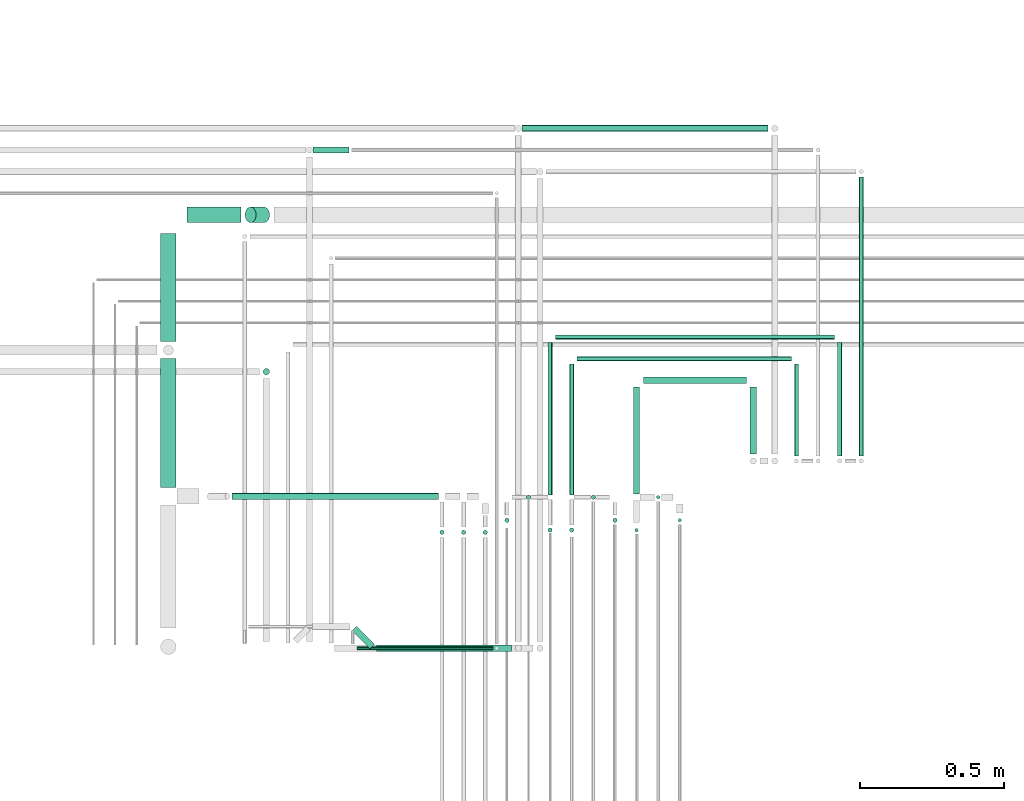
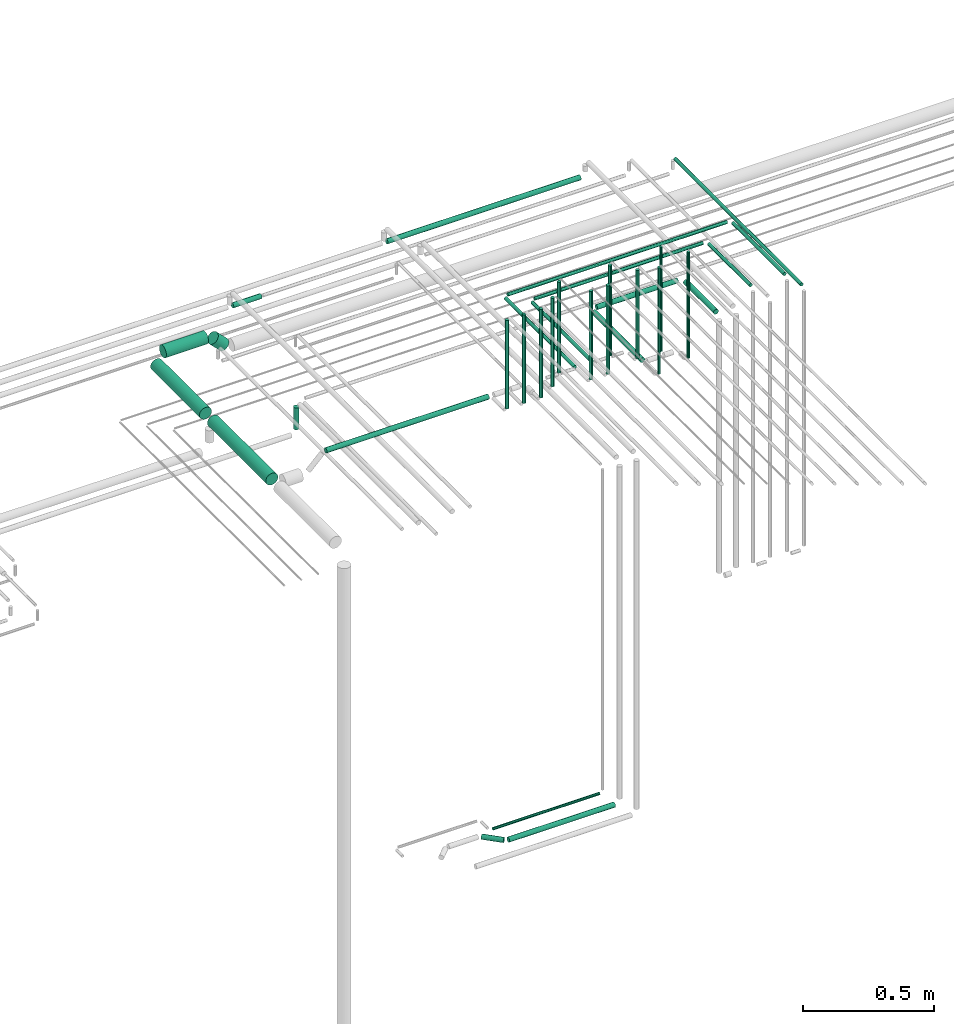
# One storey, part 45 of 65: 33 flow segments.
"""IFC2X3 building model written with IfcOpenShell, lengths in millimetres."""

from ifc_helpers import new_model, entity, si_unit, converted_unit, derived_unit, direction, frame, frame_2d, origin, origin_2d_with_axis, place, context, subcontext, project, spatial, circle, extrude, type_object, element, save


model = new_model("IFC2X3")

# Units and contexts
model_context = context("Model", 3, precision=0.01, world=origin(), true_north=direction((6.12303176911189e-17, 1.0)))
body_context = subcontext(model_context, "Body", "Model", "MODEL_VIEW")
ifc_project = project(units=[si_unit("LENGTHUNIT", "METRE", prefix="MILLI"), si_unit("AREAUNIT", "SQUARE_METRE"), si_unit("VOLUMEUNIT", "CUBIC_METRE"), converted_unit("PLANEANGLEUNIT", "DEGREE", entity("IfcRatioMeasure", 0.0174532925199433), si_unit("PLANEANGLEUNIT", "RADIAN"), dimensions=[0, 0, 0, 0, 0, 0, 0]), si_unit("MASSUNIT", "GRAM", prefix="KILO"), derived_unit("MASSDENSITYUNIT", [(si_unit("MASSUNIT", "GRAM", prefix="KILO"), 1), (si_unit("LENGTHUNIT", "METRE"), -3)]), derived_unit("MOMENTOFINERTIAUNIT", [(si_unit("LENGTHUNIT", "METRE"), 4)]), si_unit("TIMEUNIT", "SECOND"), si_unit("FREQUENCYUNIT", "HERTZ"), si_unit("THERMODYNAMICTEMPERATUREUNIT", "DEGREE_CELSIUS"), derived_unit("THERMALTRANSMITTANCEUNIT", [(si_unit("MASSUNIT", "GRAM", prefix="KILO"), 1), (si_unit("THERMODYNAMICTEMPERATUREUNIT", "KELVIN"), -1), (si_unit("TIMEUNIT", "SECOND"), -3)]), derived_unit("VOLUMETRICFLOWRATEUNIT", [(si_unit("LENGTHUNIT", "METRE"), 3), (si_unit("TIMEUNIT", "SECOND"), -1)]), derived_unit("MASSFLOWRATEUNIT", [(si_unit("MASSUNIT", "GRAM", prefix="KILO"), 1), (si_unit("TIMEUNIT", "SECOND"), -1)]), derived_unit("ROTATIONALFREQUENCYUNIT", [(si_unit("TIMEUNIT", "SECOND"), -1)]), si_unit("ELECTRICCURRENTUNIT", "AMPERE"), si_unit("ELECTRICVOLTAGEUNIT", "VOLT"), si_unit("POWERUNIT", "WATT"), si_unit("FORCEUNIT", "NEWTON", prefix="KILO"), si_unit("ILLUMINANCEUNIT", "LUX"), si_unit("LUMINOUSFLUXUNIT", "LUMEN"), si_unit("LUMINOUSINTENSITYUNIT", "CANDELA"), derived_unit("USERDEFINED", [(si_unit("MASSUNIT", "GRAM", prefix="KILO"), -1), (si_unit("LENGTHUNIT", "METRE"), -2), (si_unit("TIMEUNIT", "SECOND"), 3), (si_unit("LUMINOUSFLUXUNIT", "LUMEN"), 1)]), derived_unit("LINEARVELOCITYUNIT", [(si_unit("LENGTHUNIT", "METRE"), 1), (si_unit("TIMEUNIT", "SECOND"), -1)]), si_unit("PRESSUREUNIT", "PASCAL"), derived_unit("USERDEFINED", [(si_unit("LENGTHUNIT", "METRE"), -2), (si_unit("MASSUNIT", "GRAM", prefix="KILO"), 1), (si_unit("TIMEUNIT", "SECOND"), -2)]), derived_unit("LINEARFORCEUNIT", [(si_unit("MASSUNIT", "GRAM", prefix="KILO"), 1), (si_unit("LENGTHUNIT", "METRE"), 1), (si_unit("TIMEUNIT", "SECOND"), -2), (si_unit("LENGTHUNIT", "METRE"), -1)]), derived_unit("PLANARFORCEUNIT", [(si_unit("MASSUNIT", "GRAM", prefix="KILO"), 1), (si_unit("LENGTHUNIT", "METRE"), 1), (si_unit("TIMEUNIT", "SECOND"), -2), (si_unit("LENGTHUNIT", "METRE"), -2)])], contexts=[model_context])

# Site, building, storey
site_placement = place(None, frame((0.0, -0.00077364408347762, 0.0)))
site = spatial("IfcSite", under=ifc_project, at=site_placement, CompositionType="ELEMENT")
building_placement = place(site_placement, origin())
building = spatial("IfcBuilding", under=site, at=building_placement, CompositionType="ELEMENT")
storey_placement = place(building_placement, frame((0.0, 0.0, 19800.0)))
storey = spatial("IfcBuildingStorey", under=building, at=storey_placement, CompositionType="ELEMENT", Elevation=19800.0)

# Flow segments
pipe_segment_type = type_object("IfcPipeSegmentType", PredefinedType="NOTDEFINED")
flow_segment_1_placement = place(storey_placement, frame((67102.5166110417, 8339.14924977607, 2612.40472776409)))
element("IfcFlowSegment", 1, at=flow_segment_1_placement, inside=storey, type_object=pipe_segment_type, context=body_context, shape_type="SweptSolid", body=[
    extrude(circle(Radius=11.0, at=origin_2d_with_axis()), frame((12.5952722359134, 0.0, 12.5952722359177), z_axis=(0.0, 1.0, 0.0), x_axis=(1.0, 0.0, 0.0)), (0.0, 0.0, 1.0), 232.000000000011),
])
flow_segment_2_placement = place(storey_placement, frame((66734.1118832777, 8582.55397754016, 2612.40472776409)))
element("IfcFlowSegment", 2, at=flow_segment_2_placement, inside=storey, type_object=pipe_segment_type, context=body_context, shape_type="SweptSolid", body=[
    extrude(circle(Radius=11.0, at=frame_2d((1.08286712929839e-12, 0.0), x_axis=(1.0, 0.0))), frame((0.0, 12.5952722359188, 12.5952722359177), z_axis=(1.0, 0.0, 0.0), x_axis=(0.0, 1.0, 0.0)), (0.0, 0.0, 1.0), 356.999999999997),
])
flow_segment_3_placement = place(storey_placement, frame((66312.1118832777, 9456.85739924043, 2537.40472776408)))
element("IfcFlowSegment", 3, at=flow_segment_3_placement, inside=storey, type_object=pipe_segment_type, context=body_context, shape_type="SweptSolid", body=[
    extrude(circle(Radius=11.0, at=origin_2d_with_axis()), frame((0.0, 12.5952722359156, 12.5952722359177), z_axis=(1.0, 0.0, 0.0), x_axis=(0.0, 1.0, 0.0)), (0.0, 0.0, 1.0), 853.999999999996),
])
flow_segment_4_placement = place(storey_placement, frame((65150.1118832777, 9140.85739924042, 2596.4047277641)))
element("IfcFlowSegment", 4, at=flow_segment_4_placement, inside=storey, type_object=pipe_segment_type, context=body_context, shape_type="SweptSolid", body=[
    extrude(circle(Radius=27.0, at=origin_2d_with_axis()), frame((0.0, 28.5952722359206, 28.5952722359141), z_axis=(1.0, 0.0, 0.0), x_axis=(0.0, -1.0, 0.0)), (0.0, 0.0, 1.0), 186.309938476019),
])
flow_segment_5_placement = place(storey_placement, frame((65349.8768020495, 9140.85739924042, 2543.45498029576)))
element("IfcFlowSegment", 5, at=flow_segment_5_placement, inside=storey, type_object=pipe_segment_type, context=body_context, shape_type="SweptSolid", body=[
    extrude(circle(Radius=27.0, at=frame_2d((0.0, -3.06281076100376e-12), x_axis=(1.0, 0.0))), frame((20.687155327948, 28.5952722359163, 67.4028840805148), z_axis=(0.70710678118658, 0.0, -0.707106781186515), x_axis=(0.0, -1.0, 0.0)), (0.0, 0.0, 1.0), 66.0660171780201),
])
flow_segment_6_placement = place(storey_placement, frame((66702.5166110418, 8067.55397754015, 2639.0)))
element("IfcFlowSegment", 6, at=flow_segment_6_placement, inside=storey, type_object=pipe_segment_type, context=body_context, shape_type="SweptSolid", body=[
    extrude(circle(Radius=6.0, at=origin_2d_with_axis()), frame((7.59527223591454, 7.59527223591562, 0.0), z_axis=(0.0, 0.0, 1.0), x_axis=(-1.0, 0.0, 0.0)), (0.0, 0.0, 1.0), 497.000000000008),
])
flow_segment_7_placement = place(storey_placement, frame((66697.5166110418, 8201.27656890378, 2612.40472776408)))
element("IfcFlowSegment", 7, at=flow_segment_7_placement, inside=storey, type_object=pipe_segment_type, context=body_context, shape_type="SweptSolid", body=[
    extrude(circle(Radius=11.0, at=frame_2d((8.66293703438714e-12, 0.0), x_axis=(1.0, 0.0))), frame((12.5952722359134, 0.0, 12.5952722359177), z_axis=(0.0, 1.0, 0.0), x_axis=(-1.0, 0.0, 0.0)), (0.0, 0.0, 1.0), 369.872680872293),
])
flow_segment_8_placement = place(storey_placement, frame((66777.5166110418, 8181.68129666787, 2649.0)))
element("IfcFlowSegment", 8, at=flow_segment_8_placement, inside=storey, type_object=pipe_segment_type, context=body_context, shape_type="SweptSolid", body=[
    extrude(circle(Radius=6.0, at=origin_2d_with_axis()), frame((7.59527223591454, 7.59527223591562, 0.0), z_axis=(0.0, 0.0, 1.0), x_axis=(-1.0, 0.0, 0.0)), (0.0, 0.0, 1.0), 486.999999999993),
])
flow_segment_9_placement = place(storey_placement, frame((66852.5166110418, 8101.68129666787, 2639.0)))
element("IfcFlowSegment", 9, at=flow_segment_9_placement, inside=storey, type_object=pipe_segment_type, context=body_context, shape_type="SweptSolid", body=[
    extrude(circle(Radius=6.0, at=frame_2d((0.0, -1.08286712929839e-12), x_axis=(1.0, 0.0))), frame((7.59527223591454, 7.59527223591454, 0.0), z_axis=(0.0, 0.0, 1.0), x_axis=(-1.0, 0.0, 0.0)), (0.0, 0.0, 1.0), 497.000000000008),
])
flow_segment_10_placement = place(storey_placement, frame((67256.0166110417, 8333.14924977606, 2690.90472776409)))
element("IfcFlowSegment", 10, at=flow_segment_10_placement, inside=storey, type_object=pipe_segment_type, context=body_context, shape_type="SweptSolid", body=[
    extrude(circle(Radius=7.5, at=origin_2d_with_axis()), frame((9.09527223591419, 0.0, 9.09527223591419), z_axis=(0.0, 1.0, 0.0), x_axis=(1.0, 0.0, 0.0)), (0.0, 0.0, 1.0), 319.000000000012),
])
flow_segment_11_placement = place(storey_placement, frame((66503.1118832777, 8661.05397754016, 2690.90472776409)))
element("IfcFlowSegment", 11, at=flow_segment_11_placement, inside=storey, type_object=pipe_segment_type, context=body_context, shape_type="SweptSolid", body=[
    extrude(circle(Radius=7.5, at=frame_2d((-1.08286712929839e-12, 0.0), x_axis=(1.0, 0.0))), frame((0.0, 9.09527223591853, 9.09527223591419), z_axis=(1.0, 0.0, 0.0), x_axis=(0.0, 1.0, 0.0)), (0.0, 0.0, 1.0), 744.000000000013),
])
flow_segment_12_placement = place(storey_placement, frame((67481.0166110417, 8333.14924977605, 2615.9047277641)))
element("IfcFlowSegment", 12, at=flow_segment_12_placement, inside=storey, type_object=pipe_segment_type, context=body_context, shape_type="SweptSolid", body=[
    extrude(circle(Radius=7.5, at=origin_2d_with_axis()), frame((9.09527223591419, 0.0, 9.09527223591419), z_axis=(0.0, 1.0, 0.0), x_axis=(1.0, 0.0, 0.0)), (0.0, 0.0, 1.0), 968.303421700285),
])
flow_segment_13_placement = place(storey_placement, frame((67406.0166110417, 8333.14924977606, 2690.90472776409)))
element("IfcFlowSegment", 13, at=flow_segment_13_placement, inside=storey, type_object=pipe_segment_type, context=body_context, shape_type="SweptSolid", body=[
    extrude(circle(Radius=7.5, at=origin_2d_with_axis()), frame((9.09527223591419, 0.0, 9.09527223591419), z_axis=(0.0, 1.0, 0.0), x_axis=(1.0, 0.0, 0.0)), (0.0, 0.0, 1.0), 394.000000000012),
])
flow_segment_14_placement = place(storey_placement, frame((66428.1118832777, 8736.05397754016, 2690.90472776409)))
element("IfcFlowSegment", 14, at=flow_segment_14_placement, inside=storey, type_object=pipe_segment_type, context=body_context, shape_type="SweptSolid", body=[
    extrude(circle(Radius=7.5, at=frame_2d((1.08286712929839e-12, 0.0), x_axis=(1.0, 0.0))), frame((0.0, 9.09527223591853, 9.09527223591419), z_axis=(1.0, 0.0, 0.0), x_axis=(0.0, 1.0, 0.0)), (0.0, 0.0, 1.0), 969.000000000005),
])
flow_segment_15_placement = place(storey_placement, frame((66476.0166110418, 8066.05397754015, 2718.0)))
element("IfcFlowSegment", 15, at=flow_segment_15_placement, inside=storey, type_object=pipe_segment_type, context=body_context, shape_type="SweptSolid", body=[
    extrude(circle(Radius=7.5, at=origin_2d_with_axis()), frame((9.09527223591419, 9.09527223591636, 0.0), z_axis=(0.0, 0.0, 1.0), x_axis=(-1.0, 0.0, 0.0)), (0.0, 0.0, 1.0), 414.000000000006),
])
flow_segment_16_placement = place(storey_placement, frame((66476.0166110417, 8197.27656890379, 2690.90472776409)))
element("IfcFlowSegment", 16, at=flow_segment_16_placement, inside=storey, type_object=pipe_segment_type, context=body_context, shape_type="SweptSolid", body=[
    extrude(circle(Radius=7.5, at=origin_2d_with_axis()), frame((9.09527223593152, 0.0, 9.09527223591419), z_axis=(0.0, 1.0, 0.0), x_axis=(1.0, 0.0, 0.0)), (0.0, 0.0, 1.0), 454.872680872296),
])
flow_segment_17_placement = place(storey_placement, frame((66551.0166110418, 8180.18129666787, 2708.0)))
element("IfcFlowSegment", 17, at=flow_segment_17_placement, inside=storey, type_object=pipe_segment_type, context=body_context, shape_type="SweptSolid", body=[
    extrude(circle(Radius=7.5, at=origin_2d_with_axis()), frame((9.09527223591419, 9.09527223591636, 0.0), z_axis=(0.0, 0.0, 1.0), x_axis=(-1.0, 0.0, 0.0)), (0.0, 0.0, 1.0), 421.999999999999),
])
flow_segment_18_placement = place(storey_placement, frame((66626.0166110418, 8100.18129666787, 2718.0)))
element("IfcFlowSegment", 18, at=flow_segment_18_placement, inside=storey, type_object=pipe_segment_type, context=body_context, shape_type="SweptSolid", body=[
    extrude(circle(Radius=7.5, at=frame_2d((-8.66293703438714e-12, 0.0), x_axis=(1.0, 0.0))), frame((9.09527223590553, 9.09527223591636, 0.0), z_axis=(0.0, 0.0, 1.0), x_axis=(-1.0, 0.0, 0.0)), (0.0, 0.0, 1.0), 411.999999999997),
])
flow_segment_19_placement = place(storey_placement, frame((66401.0166110417, 8066.05397754015, 2718.0)))
element("IfcFlowSegment", 19, at=flow_segment_19_placement, inside=storey, type_object=pipe_segment_type, context=body_context, shape_type="SweptSolid", body=[
    extrude(circle(Radius=7.5, at=origin_2d_with_axis()), frame((9.09527223591419, 9.09527223591636, 0.0), z_axis=(0.0, 0.0, 1.0), x_axis=(-1.0, 0.0, 0.0)), (0.0, 0.0, 1.0), 414.000000000006),
])
flow_segment_20_placement = place(storey_placement, frame((66401.0166110417, 8197.27656890378, 2690.90472776409)))
element("IfcFlowSegment", 20, at=flow_segment_20_placement, inside=storey, type_object=pipe_segment_type, context=body_context, shape_type="SweptSolid", body=[
    extrude(circle(Radius=7.5, at=origin_2d_with_axis()), frame((9.09527223591419, 0.0, 9.09527223591419), z_axis=(0.0, 1.0, 0.0), x_axis=(1.0, 0.0, 0.0)), (0.0, 0.0, 1.0), 529.872680872288),
])
flow_segment_21_placement = place(storey_placement, frame((66326.0166110417, 8180.18129666787, 2707.0)))
element("IfcFlowSegment", 21, at=flow_segment_21_placement, inside=storey, type_object=pipe_segment_type, context=body_context, shape_type="SweptSolid", body=[
    extrude(circle(Radius=7.5, at=frame_2d((-8.66293703438714e-12, 0.0), x_axis=(1.0, 0.0))), frame((9.09527223590553, 9.09527223591636, 0.0), z_axis=(0.0, 0.0, 1.0), x_axis=(-1.0, 0.0, 0.0)), (0.0, 0.0, 1.0), 425.000000000007),
])
flow_segment_22_placement = place(storey_placement, frame((66251.0166110417, 8100.18129666787, 2718.0)))
element("IfcFlowSegment", 22, at=flow_segment_22_placement, inside=storey, type_object=pipe_segment_type, context=body_context, shape_type="SweptSolid", body=[
    extrude(circle(Radius=7.5, at=origin_2d_with_axis()), frame((9.09527223591419, 9.09527223591636, 0.0), z_axis=(0.0, 0.0, 1.0), x_axis=(-1.0, 0.0, 0.0)), (0.0, 0.0, 1.0), 414.000000000006),
])
flow_segment_23_placement = place(storey_placement, frame((66176.0166110417, 8058.31913480315, 2718.0)))
element("IfcFlowSegment", 23, at=flow_segment_23_placement, inside=storey, type_object=pipe_segment_type, context=body_context, shape_type="SweptSolid", body=[
    extrude(circle(Radius=7.5, at=frame_2d((-8.66293703438714e-12, 0.0), x_axis=(1.0, 0.0))), frame((9.09527223590553, 9.09527223591636, 0.0), z_axis=(0.0, 0.0, 1.0), x_axis=(-1.0, 0.0, 0.0)), (0.0, 0.0, 1.0), 414.00000000001),
])
flow_segment_24_placement = place(storey_placement, frame((66101.0166110417, 8058.31913480315, 2718.0)))
element("IfcFlowSegment", 24, at=flow_segment_24_placement, inside=storey, type_object=pipe_segment_type, context=body_context, shape_type="SweptSolid", body=[
    extrude(circle(Radius=7.5, at=origin_2d_with_axis()), frame((9.09527223591419, 9.09527223591636, 0.0), z_axis=(0.0, 0.0, 1.0), x_axis=(-1.0, 0.0, 0.0)), (0.0, 0.0, 1.0), 414.000000000018),
])
flow_segment_25_placement = place(storey_placement, frame((66026.0166110417, 8058.31913480315, 2718.0)))
element("IfcFlowSegment", 25, at=flow_segment_25_placement, inside=storey, type_object=pipe_segment_type, context=body_context, shape_type="SweptSolid", body=[
    extrude(circle(Radius=7.5, at=frame_2d((-8.66293703438714e-12, 0.0), x_axis=(1.0, 0.0))), frame((9.09527223590553, 9.09527223591636, 0.0), z_axis=(0.0, 0.0, 1.0), x_axis=(-1.0, 0.0, 0.0)), (0.0, 0.0, 1.0), 414.000000000018),
])
flow_segment_26_placement = place(storey_placement, frame((65305.4218217537, 8179.81913480314, 2687.40472776409)))
element("IfcFlowSegment", 26, at=flow_segment_26_placement, inside=storey, type_object=pipe_segment_type, context=body_context, shape_type="SweptSolid", body=[
    extrude(circle(Radius=11.0, at=origin_2d_with_axis()), frame((0.0, 12.5952722359156, 12.5952722359177), z_axis=(1.0, 0.0, 0.0), x_axis=(0.0, -1.0, 0.0)), (0.0, 0.0, 1.0), 717.690061523958),
])
flow_segment_27_placement = place(storey_placement, frame((65412.5166110418, 8612.40493375773, 2499.0)))
element("IfcFlowSegment", 27, at=flow_segment_27_placement, inside=storey, type_object=pipe_segment_type, context=body_context, shape_type="SweptSolid", body=[
    extrude(circle(Radius=11.0, at=origin_2d_with_axis()), frame((12.5952722359134, 12.5952722359156, 0.0)), (0.0, 0.0, 1.0), 102.000000000011),
])
flow_segment_28_placement = place(storey_placement, frame((65587.1118832777, 9381.85739924042, 2537.40472776409)))
element("IfcFlowSegment", 28, at=flow_segment_28_placement, inside=storey, type_object=pipe_segment_type, context=body_context, shape_type="SweptSolid", body=[
    extrude(circle(Radius=11.0, at=origin_2d_with_axis()), frame((0.0, 12.5952722359286, 12.5952722359177), z_axis=(1.0, 0.0, 0.0), x_axis=(0.0, -1.0, 0.0)), (0.0, 0.0, 1.0), 124.999999999989),
])
flow_segment_29_placement = place(storey_placement, frame((65056.5166110417, 8730.00020599365, 2596.4047277641)))
element("IfcFlowSegment", 29, at=flow_segment_29_placement, inside=storey, type_object=pipe_segment_type, context=body_context, shape_type="SweptSolid", body=[
    extrude(circle(Radius=27.0, at=frame_2d((8.66293703438714e-12, 0.0), x_axis=(1.0, 0.0))), frame((28.5952722359271, 0.0, 28.5952722359141), z_axis=(0.0, 1.0, 0.0), x_axis=(-1.0, 0.0, 0.0)), (0.0, 0.0, 1.0), 374.45246548269),
])
flow_segment_30_placement = place(storey_placement, frame((65808.1101866821, 7652.55397759734, 1012.40472776406)))
element("IfcFlowSegment", 30, at=flow_segment_30_placement, inside=storey, type_object=pipe_segment_type, context=body_context, shape_type="SweptSolid", body=[
    extrude(circle(Radius=11.0, at=frame_2d((2.16573425859679e-12, 0.0), x_axis=(1.0, 0.0))), frame((0.0, 12.5952722359188, 12.5952722359177), z_axis=(1.0, 0.0, 0.0), x_axis=(0.0, 1.0, 0.0)), (0.0, 0.0, 1.0), 468.001696595595),
])
flow_segment_31_placement = place(storey_placement, frame((65721.1007008838, 7662.13976403496, 1012.40472776408)))
element("IfcFlowSegment", 31, at=flow_segment_31_placement, inside=storey, type_object=pipe_segment_type, context=body_context, shape_type="SweptSolid", body=[
    extrude(circle(Radius=11.0, at=origin_2d_with_axis()), frame((71.6455247676051, 9.37344682896681, 12.5952722359177), z_axis=(-0.707106781186388, 0.707106781186707, 0.0), x_axis=(0.707106781186707, 0.707106781186388, 0.0)), (0.0, 0.0, 1.0), 88.0660171779912),
])
flow_segment_32_placement = place(storey_placement, frame((65739.1118832777, 7657.55397759733, 1092.40472776406)))
element("IfcFlowSegment", 32, at=flow_segment_32_placement, inside=storey, type_object=pipe_segment_type, context=body_context, shape_type="SweptSolid", body=[
    extrude(circle(Radius=6.0, at=frame_2d((6.49720277579036e-12, 0.0), x_axis=(1.0, 0.0))), frame((0.0, 7.5952722359232, 7.59527223591454), z_axis=(1.0, 0.0, 0.0), x_axis=(0.0, 1.0, 0.0)), (0.0, 0.0, 1.0), 472.000000000005),
])
flow_segment_33_placement = place(storey_placement, frame((65056.5166110417, 8222.41440703907, 2596.40472776409)))
element("IfcFlowSegment", 33, at=flow_segment_33_placement, inside=storey, type_object=pipe_segment_type, context=body_context, shape_type="SweptSolid", body=[
    extrude(circle(Radius=27.0, at=frame_2d((8.66293703438714e-12, -4.33146851719357e-12), x_axis=(1.0, 0.0))), frame((28.5952722359271, 0.0, 28.5952722359184), z_axis=(0.0, 1.0, 0.0), x_axis=(-1.0, 0.0, 0.0)), (0.0, 0.0, 1.0), 447.585798954584),
])

save(model, "model.ifc")
